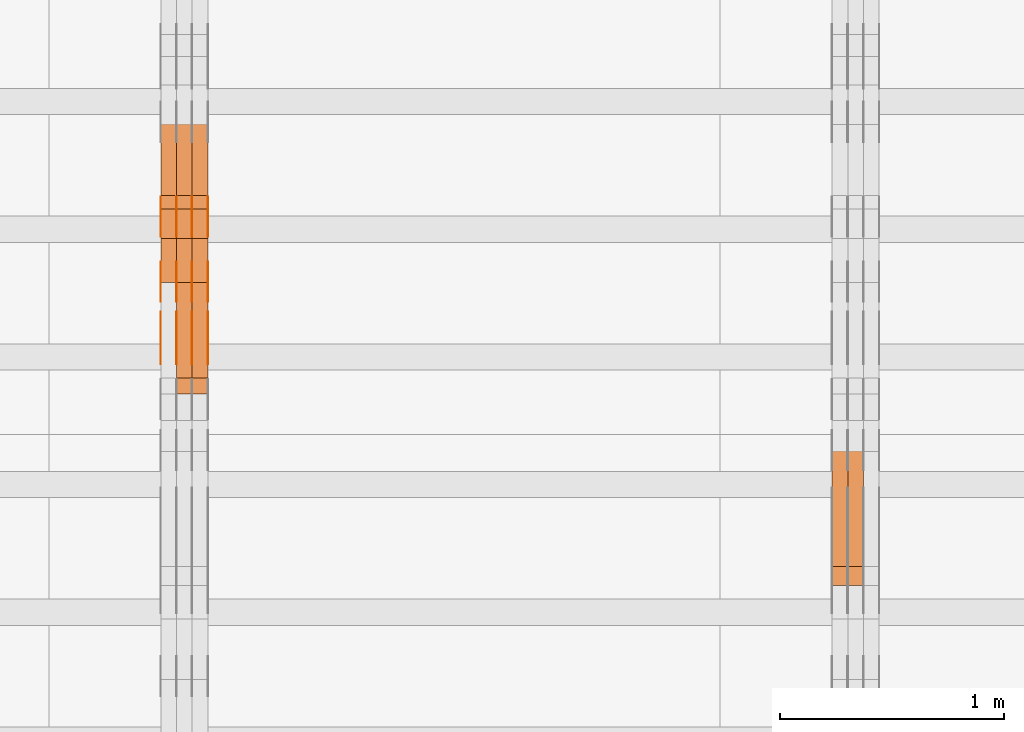
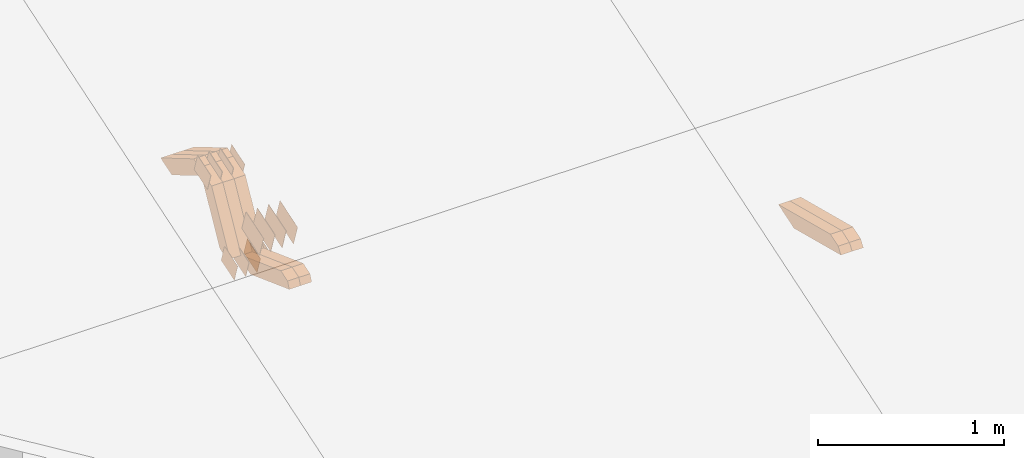
# One storey, part 135 of 385: 28 proxies.
"""IFC2X3 building model written with IfcOpenShell, lengths in millimetres."""

from ifc_helpers import new_model, entity, si_unit, converted_unit, derived_unit, direction, frame, origin, place, context, subcontext, project, spatial, polyline, outline, extrude, source, transform, mapped, material, type_object, type_shapes, element, save


model = new_model("IFC2X3")

# Units and contexts
model_context = context("Model", 3, precision=0.01, world=origin(), true_north=direction((6.12303176911189e-17, 1.0)))
body_context = subcontext(model_context, "Body", "Model", "MODEL_VIEW")
ifc_project = project(units=[si_unit("LENGTHUNIT", "METRE", prefix="MILLI"), si_unit("AREAUNIT", "SQUARE_METRE"), si_unit("VOLUMEUNIT", "CUBIC_METRE"), converted_unit("PLANEANGLEUNIT", "DEGREE", entity("IfcRatioMeasure", 0.0174532925199433), si_unit("PLANEANGLEUNIT", "RADIAN"), dimensions=[0, 0, 0, 0, 0, 0, 0]), si_unit("MASSUNIT", "GRAM", prefix="KILO"), derived_unit("MASSDENSITYUNIT", [(si_unit("MASSUNIT", "GRAM", prefix="KILO"), 1), (si_unit("LENGTHUNIT", "METRE"), -3)]), si_unit("TIMEUNIT", "SECOND"), si_unit("FREQUENCYUNIT", "HERTZ"), si_unit("THERMODYNAMICTEMPERATUREUNIT", "DEGREE_CELSIUS"), derived_unit("THERMALTRANSMITTANCEUNIT", [(si_unit("MASSUNIT", "GRAM", prefix="KILO"), 1), (si_unit("THERMODYNAMICTEMPERATUREUNIT", "KELVIN"), -1), (si_unit("TIMEUNIT", "SECOND"), -3)]), derived_unit("VOLUMETRICFLOWRATEUNIT", [(si_unit("LENGTHUNIT", "METRE"), 3), (si_unit("TIMEUNIT", "SECOND"), -1)]), si_unit("ELECTRICCURRENTUNIT", "AMPERE"), si_unit("ELECTRICVOLTAGEUNIT", "VOLT"), si_unit("POWERUNIT", "WATT"), si_unit("FORCEUNIT", "NEWTON", prefix="KILO"), si_unit("ILLUMINANCEUNIT", "LUX"), si_unit("LUMINOUSFLUXUNIT", "LUMEN"), si_unit("LUMINOUSINTENSITYUNIT", "CANDELA"), derived_unit("USERDEFINED", [(si_unit("MASSUNIT", "GRAM", prefix="KILO"), -1), (si_unit("LENGTHUNIT", "METRE"), -2), (si_unit("TIMEUNIT", "SECOND"), 3), (si_unit("LUMINOUSFLUXUNIT", "LUMEN"), 1)]), derived_unit("LINEARVELOCITYUNIT", [(si_unit("LENGTHUNIT", "METRE"), 1), (si_unit("TIMEUNIT", "SECOND"), -1)]), si_unit("PRESSUREUNIT", "PASCAL"), derived_unit("USERDEFINED", [(si_unit("LENGTHUNIT", "METRE"), -2), (si_unit("MASSUNIT", "GRAM", prefix="KILO"), 1), (si_unit("TIMEUNIT", "SECOND"), -2)])], contexts=[model_context])

# Site, building, storey
site_placement = place(None, origin())
site = spatial("IfcSite", under=ifc_project, at=site_placement, CompositionType="ELEMENT")
building_placement = place(site_placement, origin())
building = spatial("IfcBuilding", under=site, at=building_placement, CompositionType="ELEMENT")
storey_placement = place(building_placement, origin())
storey = spatial("IfcBuildingStorey", under=building, at=storey_placement, Name="Default", CompositionType="ELEMENT", Elevation=0.0)

# Proxies
ifc_material_1 = material(Name="IfcSurfaceStyle #323078")
building_element_proxy_type_1 = type_object("IfcBuildingElementProxyType", Name="T1-W11 323076", PredefinedType="NOTDEFINED", material=ifc_material_1)
shared_shape_1 = source(origin(), body_context, "Body", "SweptSolid", [
    extrude(outline(polyline([(-261.366417792209, -47.5000378467523), (260.949520182121, -47.5000378467523), (242.928845159301, -7.41559889341215e-06), (168.237407166939, 47.5000415545517), (-410.749354716152, 47.5000415545517), (-261.366417792209, -47.5000378467523)])), frame((260.949520182121, 47.5000415545517, 0.0), z_axis=(0.0, 0.0, 1.0), x_axis=(-1.0, 0.0, 0.0)), (0.0, 0.0, 1.0), 70.0),
])
type_shapes(building_element_proxy_type_1, [shared_shape_1])
proxy_1_placement = place(building_placement, frame((27315.0, 8017.44318793234, 2097.03832883996), z_axis=(-1.0, 0.0, 0.0), x_axis=(0.0, 0.968347201599873, -0.249607085543851)))
element("IfcBuildingElementProxy", 1, at=proxy_1_placement, inside=storey, type_object=building_element_proxy_type_1, material=ifc_material_1, Name="T1-W11", context=body_context, shape_type="MappedRepresentation", body=[
    mapped(shared_shape_1, transform((0.0, 0.0, 0.0), scale=1.0)),
])
ifc_material_2 = material(Name="IfcSurfaceStyle #323012")
building_element_proxy_type_2 = type_object("IfcBuildingElementProxyType", Name="T1-W11 323010", PredefinedType="NOTDEFINED", material=ifc_material_2)
shared_shape_2 = source(origin(), body_context, "Body", "SweptSolid", [
    extrude(outline(polyline([(-261.366417792209, -47.5000378467523), (260.949520182121, -47.5000378467523), (242.928845159301, -7.41559889341215e-06), (168.237407166939, 47.5000415545517), (-410.749354716152, 47.5000415545517), (-261.366417792209, -47.5000378467523)])), frame((260.949520182121, 47.5000415545517, 0.0), z_axis=(0.0, 0.0, 1.0), x_axis=(-1.0, 0.0, 0.0)), (0.0, 0.0, 1.0), 70.0),
])
type_shapes(building_element_proxy_type_2, [shared_shape_2])
proxy_2_placement = place(building_placement, frame((27245.0, 8017.44318793234, 2097.03832883996), z_axis=(-1.0, 0.0, 0.0), x_axis=(0.0, 0.968347201599873, -0.249607085543851)))
element("IfcBuildingElementProxy", 2, at=proxy_2_placement, inside=storey, type_object=building_element_proxy_type_2, material=ifc_material_2, Name="T1-W11", context=body_context, shape_type="MappedRepresentation", body=[
    mapped(shared_shape_2, transform((0.0, 0.0, 0.0), scale=1.0)),
])
ifc_material_3 = material(Name="IfcSurfaceStyle #314830")
building_element_proxy_type_3 = type_object("IfcBuildingElementProxyType", PredefinedType="NOTDEFINED", material=ifc_material_3)
shared_shape_3 = source(origin(), body_context, "Body", "SweptSolid", [
    extrude(outline(polyline([(-99.999644645517, -72.0000317581407), (100.000028485991, -72.0000317581407), (99.999644645517, 72.0000317581407), (-100.000028485991, 72.0000317581407), (-99.999644645517, -72.0000317581407)])), frame((100.000028485991, 72.0000317581407, 0.0), z_axis=(0.0, 0.0, 1.0), x_axis=(-1.0, 0.0, 0.0)), (0.0, 0.0, 1.0), 1.3),
])
type_shapes(building_element_proxy_type_3, [shared_shape_3])
proxy_3_placement = place(building_placement, frame((24386.3, 9012.6304394324, 2546.30522609783), z_axis=(-1.0, 0.0, 0.0), x_axis=(0.0, 0.951056516295154, 0.309016994374948)))
element("IfcBuildingElementProxy", 3, at=proxy_3_placement, inside=storey, type_object=building_element_proxy_type_3, material=ifc_material_3, context=body_context, shape_type="MappedRepresentation", body=[
    mapped(shared_shape_3, transform((0.0, 0.0, 0.0), scale=1.0)),
])
ifc_material_4 = material(Name="IfcSurfaceStyle #314773")
building_element_proxy_type_4 = type_object("IfcBuildingElementProxyType", PredefinedType="NOTDEFINED", material=ifc_material_4)
shared_shape_4 = source(origin(), body_context, "Body", "SweptSolid", [
    extrude(outline(polyline([(-99.999644645517, -72.0000317581407), (100.000028485991, -72.0000317581407), (99.999644645517, 72.0000317581407), (-100.000028485991, 72.0000317581407), (-99.999644645517, -72.0000317581407)])), frame((100.000028485991, 72.0000317581407, 0.0), z_axis=(0.0, 0.0, 1.0), x_axis=(-1.0, 0.0, 0.0)), (0.0, 0.0, 1.0), 1.3),
])
type_shapes(building_element_proxy_type_4, [shared_shape_4])
proxy_4_placement = place(building_placement, frame((24315.0, 9012.6304394324, 2546.30522609783), z_axis=(-1.0, 0.0, 0.0), x_axis=(0.0, 0.951056516295154, 0.309016994374948)))
element("IfcBuildingElementProxy", 4, at=proxy_4_placement, inside=storey, type_object=building_element_proxy_type_4, material=ifc_material_4, context=body_context, shape_type="MappedRepresentation", body=[
    mapped(shared_shape_4, transform((0.0, 0.0, 0.0), scale=1.0)),
])
ifc_material_5 = material(Name="IfcSurfaceStyle #314716")
building_element_proxy_type_5 = type_object("IfcBuildingElementProxyType", PredefinedType="NOTDEFINED", material=ifc_material_5)
shared_shape_5 = source(origin(), body_context, "Body", "SweptSolid", [
    extrude(outline(polyline([(-99.999644645517, -72.0000317581407), (100.000028485991, -72.0000317581407), (99.999644645517, 72.0000317581407), (-100.000028485991, 72.0000317581407), (-99.999644645517, -72.0000317581407)])), frame((100.000028485991, 72.0000317581407, 0.0), z_axis=(0.0, 0.0, 1.0), x_axis=(-1.0, 0.0, 0.0)), (0.0, 0.0, 1.0), 1.3),
])
type_shapes(building_element_proxy_type_5, [shared_shape_5])
proxy_5_placement = place(building_placement, frame((24316.3, 9012.6304394324, 2546.30522609783), z_axis=(-1.0, 0.0, 0.0), x_axis=(0.0, 0.951056516295154, 0.309016994374948)))
element("IfcBuildingElementProxy", 5, at=proxy_5_placement, inside=storey, type_object=building_element_proxy_type_5, material=ifc_material_5, context=body_context, shape_type="MappedRepresentation", body=[
    mapped(shared_shape_5, transform((0.0, 0.0, 0.0), scale=1.0)),
])
ifc_material_6 = material(Name="IfcSurfaceStyle #314659")
building_element_proxy_type_6 = type_object("IfcBuildingElementProxyType", PredefinedType="NOTDEFINED", material=ifc_material_6)
shared_shape_6 = source(origin(), body_context, "Body", "SweptSolid", [
    extrude(outline(polyline([(-99.999644645517, -72.0000317581407), (100.000028485991, -72.0000317581407), (99.999644645517, 72.0000317581407), (-100.000028485991, 72.0000317581407), (-99.999644645517, -72.0000317581407)])), frame((100.000028485991, 72.0000317581407, 0.0), z_axis=(0.0, 0.0, 1.0), x_axis=(-1.0, 0.0, 0.0)), (0.0, 0.0, 1.0), 1.29999999999998),
])
type_shapes(building_element_proxy_type_6, [shared_shape_6])
proxy_6_placement = place(building_placement, frame((24245.0, 9012.6304394324, 2546.30522609783), z_axis=(-1.0, 0.0, 0.0), x_axis=(0.0, 0.951056516295154, 0.309016994374948)))
element("IfcBuildingElementProxy", 6, at=proxy_6_placement, inside=storey, type_object=building_element_proxy_type_6, material=ifc_material_6, context=body_context, shape_type="MappedRepresentation", body=[
    mapped(shared_shape_6, transform((0.0, 0.0, 0.0), scale=1.0)),
])
ifc_material_7 = material(Name="IfcSurfaceStyle #314602")
building_element_proxy_type_7 = type_object("IfcBuildingElementProxyType", PredefinedType="NOTDEFINED", material=ifc_material_7)
shared_shape_7 = source(origin(), body_context, "Body", "SweptSolid", [
    extrude(outline(polyline([(-99.999644645517, -72.0000317581407), (100.000028485991, -72.0000317581407), (99.999644645517, 72.0000317581407), (-100.000028485991, 72.0000317581407), (-99.999644645517, -72.0000317581407)])), frame((100.000028485991, 72.0000317581407, 0.0), z_axis=(0.0, 0.0, 1.0), x_axis=(-1.0, 0.0, 0.0)), (0.0, 0.0, 1.0), 1.29999999999998),
])
type_shapes(building_element_proxy_type_7, [shared_shape_7])
proxy_7_placement = place(building_placement, frame((24246.3, 9012.6304394324, 2546.30522609783), z_axis=(-1.0, 0.0, 0.0), x_axis=(0.0, 0.951056516295154, 0.309016994374948)))
element("IfcBuildingElementProxy", 7, at=proxy_7_placement, inside=storey, type_object=building_element_proxy_type_7, material=ifc_material_7, context=body_context, shape_type="MappedRepresentation", body=[
    mapped(shared_shape_7, transform((0.0, 0.0, 0.0), scale=1.0)),
])
ifc_material_8 = material(Name="IfcSurfaceStyle #314545")
building_element_proxy_type_8 = type_object("IfcBuildingElementProxyType", PredefinedType="NOTDEFINED", material=ifc_material_8)
shared_shape_8 = source(origin(), body_context, "Body", "SweptSolid", [
    extrude(outline(polyline([(-99.999644645517, -72.0000317581407), (100.000028485991, -72.0000317581407), (99.999644645517, 72.0000317581407), (-100.000028485991, 72.0000317581407), (-99.999644645517, -72.0000317581407)])), frame((100.000028485991, 72.0000317581407, 0.0), z_axis=(0.0, 0.0, 1.0), x_axis=(-1.0, 0.0, 0.0)), (0.0, 0.0, 1.0), 1.29999999999999),
])
type_shapes(building_element_proxy_type_8, [shared_shape_8])
proxy_8_placement = place(building_placement, frame((24175.0, 9012.6304394324, 2546.30522609783), z_axis=(-1.0, 0.0, 0.0), x_axis=(0.0, 0.951056516295154, 0.309016994374948)))
element("IfcBuildingElementProxy", 8, at=proxy_8_placement, inside=storey, type_object=building_element_proxy_type_8, material=ifc_material_8, context=body_context, shape_type="MappedRepresentation", body=[
    mapped(shared_shape_8, transform((0.0, 0.0, 0.0), scale=1.0)),
])
ifc_material_9 = material(Name="IfcSurfaceStyle #314488")
building_element_proxy_type_9 = type_object("IfcBuildingElementProxyType", PredefinedType="NOTDEFINED", material=ifc_material_9)
shared_shape_9 = source(origin(), body_context, "Body", "SweptSolid", [
    extrude(outline(polyline([(-74.9998754286207, -60.0000016373506), (74.9998605591063, -60.0000016373506), (74.9998754286244, 60.0000016373506), (-74.9998605591099, 60.0000016373506), (-74.9998754286207, -60.0000016373506)])), frame((74.9998754286244, 60.0000016373506, 0.0), z_axis=(0.0, 0.0, 1.0), x_axis=(-1.0, 0.0, 0.0)), (0.0, 0.0, 1.0), 1.3),
])
type_shapes(building_element_proxy_type_9, [shared_shape_9])
proxy_9_placement = place(building_placement, frame((24386.3, 9580.89841427132, 2615.81135078741), z_axis=(-1.0, 0.0, 0.0), x_axis=(0.0, 0.951056516295154, 0.309016994374948)))
element("IfcBuildingElementProxy", 9, at=proxy_9_placement, inside=storey, type_object=building_element_proxy_type_9, material=ifc_material_9, context=body_context, shape_type="MappedRepresentation", body=[
    mapped(shared_shape_9, transform((0.0, 0.0, 0.0), scale=1.0)),
])
ifc_material_10 = material(Name="IfcSurfaceStyle #314431")
building_element_proxy_type_10 = type_object("IfcBuildingElementProxyType", PredefinedType="NOTDEFINED", material=ifc_material_10)
shared_shape_10 = source(origin(), body_context, "Body", "SweptSolid", [
    extrude(outline(polyline([(-74.9998754286207, -60.0000016373506), (74.9998605591063, -60.0000016373506), (74.9998754286244, 60.0000016373506), (-74.9998605591099, 60.0000016373506), (-74.9998754286207, -60.0000016373506)])), frame((74.9998754286244, 60.0000016373506, 0.0), z_axis=(0.0, 0.0, 1.0), x_axis=(-1.0, 0.0, 0.0)), (0.0, 0.0, 1.0), 1.3),
])
type_shapes(building_element_proxy_type_10, [shared_shape_10])
proxy_10_placement = place(building_placement, frame((24315.0, 9580.89841427132, 2615.81135078741), z_axis=(-1.0, 0.0, 0.0), x_axis=(0.0, 0.951056516295154, 0.309016994374948)))
element("IfcBuildingElementProxy", 10, at=proxy_10_placement, inside=storey, type_object=building_element_proxy_type_10, material=ifc_material_10, context=body_context, shape_type="MappedRepresentation", body=[
    mapped(shared_shape_10, transform((0.0, 0.0, 0.0), scale=1.0)),
])
ifc_material_11 = material(Name="IfcSurfaceStyle #314374")
building_element_proxy_type_11 = type_object("IfcBuildingElementProxyType", PredefinedType="NOTDEFINED", material=ifc_material_11)
shared_shape_11 = source(origin(), body_context, "Body", "SweptSolid", [
    extrude(outline(polyline([(-74.9998754286207, -60.0000016373506), (74.9998605591063, -60.0000016373506), (74.9998754286244, 60.0000016373506), (-74.9998605591099, 60.0000016373506), (-74.9998754286207, -60.0000016373506)])), frame((74.9998754286244, 60.0000016373506, 0.0), z_axis=(0.0, 0.0, 1.0), x_axis=(-1.0, 0.0, 0.0)), (0.0, 0.0, 1.0), 1.3),
])
type_shapes(building_element_proxy_type_11, [shared_shape_11])
proxy_11_placement = place(building_placement, frame((24316.3, 9580.89841427132, 2615.81135078741), z_axis=(-1.0, 0.0, 0.0), x_axis=(0.0, 0.951056516295154, 0.309016994374948)))
element("IfcBuildingElementProxy", 11, at=proxy_11_placement, inside=storey, type_object=building_element_proxy_type_11, material=ifc_material_11, context=body_context, shape_type="MappedRepresentation", body=[
    mapped(shared_shape_11, transform((0.0, 0.0, 0.0), scale=1.0)),
])
ifc_material_12 = material(Name="IfcSurfaceStyle #314317")
building_element_proxy_type_12 = type_object("IfcBuildingElementProxyType", PredefinedType="NOTDEFINED", material=ifc_material_12)
shared_shape_12 = source(origin(), body_context, "Body", "SweptSolid", [
    extrude(outline(polyline([(-74.9998754286207, -60.0000016373506), (74.9998605591063, -60.0000016373506), (74.9998754286244, 60.0000016373506), (-74.9998605591099, 60.0000016373506), (-74.9998754286207, -60.0000016373506)])), frame((74.9998754286244, 60.0000016373506, 0.0), z_axis=(0.0, 0.0, 1.0), x_axis=(-1.0, 0.0, 0.0)), (0.0, 0.0, 1.0), 1.29999999999999),
])
type_shapes(building_element_proxy_type_12, [shared_shape_12])
proxy_12_placement = place(building_placement, frame((24245.0, 9580.89841427132, 2615.81135078741), z_axis=(-1.0, 0.0, 0.0), x_axis=(0.0, 0.951056516295154, 0.309016994374948)))
element("IfcBuildingElementProxy", 12, at=proxy_12_placement, inside=storey, type_object=building_element_proxy_type_12, material=ifc_material_12, context=body_context, shape_type="MappedRepresentation", body=[
    mapped(shared_shape_12, transform((0.0, 0.0, 0.0), scale=1.0)),
])
ifc_material_13 = material(Name="IfcSurfaceStyle #314260")
building_element_proxy_type_13 = type_object("IfcBuildingElementProxyType", PredefinedType="NOTDEFINED", material=ifc_material_13)
shared_shape_13 = source(origin(), body_context, "Body", "SweptSolid", [
    extrude(outline(polyline([(-74.9998754286207, -60.0000016373506), (74.9998605591063, -60.0000016373506), (74.9998754286244, 60.0000016373506), (-74.9998605591099, 60.0000016373506), (-74.9998754286207, -60.0000016373506)])), frame((74.9998754286244, 60.0000016373506, 0.0), z_axis=(0.0, 0.0, 1.0), x_axis=(-1.0, 0.0, 0.0)), (0.0, 0.0, 1.0), 1.29999999999999),
])
type_shapes(building_element_proxy_type_13, [shared_shape_13])
proxy_13_placement = place(building_placement, frame((24246.3, 9580.89841427132, 2615.81135078741), z_axis=(-1.0, 0.0, 0.0), x_axis=(0.0, 0.951056516295154, 0.309016994374948)))
element("IfcBuildingElementProxy", 13, at=proxy_13_placement, inside=storey, type_object=building_element_proxy_type_13, material=ifc_material_13, context=body_context, shape_type="MappedRepresentation", body=[
    mapped(shared_shape_13, transform((0.0, 0.0, 0.0), scale=1.0)),
])
ifc_material_14 = material(Name="IfcSurfaceStyle #314203")
building_element_proxy_type_14 = type_object("IfcBuildingElementProxyType", PredefinedType="NOTDEFINED", material=ifc_material_14)
shared_shape_14 = source(origin(), body_context, "Body", "SweptSolid", [
    extrude(outline(polyline([(-74.9998754286207, -60.0000016373506), (74.9998605591063, -60.0000016373506), (74.9998754286244, 60.0000016373506), (-74.9998605591099, 60.0000016373506), (-74.9998754286207, -60.0000016373506)])), frame((74.9998754286244, 60.0000016373506, 0.0), z_axis=(0.0, 0.0, 1.0), x_axis=(-1.0, 0.0, 0.0)), (0.0, 0.0, 1.0), 1.29999999999999),
])
type_shapes(building_element_proxy_type_14, [shared_shape_14])
proxy_14_placement = place(building_placement, frame((24175.0, 9580.89841427132, 2615.81135078741), z_axis=(-1.0, 0.0, 0.0), x_axis=(0.0, 0.951056516295154, 0.309016994374948)))
element("IfcBuildingElementProxy", 14, at=proxy_14_placement, inside=storey, type_object=building_element_proxy_type_14, material=ifc_material_14, context=body_context, shape_type="MappedRepresentation", body=[
    mapped(shared_shape_14, transform((0.0, 0.0, 0.0), scale=1.0)),
])
ifc_material_15 = material(Name="IfcSurfaceStyle #313462")
building_element_proxy_type_15 = type_object("IfcBuildingElementProxyType", PredefinedType="NOTDEFINED", material=ifc_material_15)
shared_shape_15 = source(origin(), body_context, "Body", "SweptSolid", [
    extrude(outline(polyline([(-75.0008041947458, -59.9996998629349), (75.0007893252423, -59.9996998629349), (75.0008041947458, 59.9996998629349), (-75.0007893252423, 59.9996998629349), (-75.0008041947458, -59.9996998629349)])), frame((75.0008041947458, 60.0002282421692, 0.0), z_axis=(0.0, 0.0, 1.0), x_axis=(-1.0, 0.0, 0.0)), (0.0, 0.0, 1.0), 1.3),
])
type_shapes(building_element_proxy_type_15, [shared_shape_15])
proxy_15_placement = place(building_placement, frame((24386.3, 9291.048828125, 2194.94482421875), z_axis=(-1.0, 0.0, 0.0), x_axis=(0.0, 0.951056516295124, 0.309016994375039)))
element("IfcBuildingElementProxy", 15, at=proxy_15_placement, inside=storey, type_object=building_element_proxy_type_15, material=ifc_material_15, context=body_context, shape_type="MappedRepresentation", body=[
    mapped(shared_shape_15, transform((0.0, 0.0, 0.0), scale=1.0)),
])
ifc_material_16 = material(Name="IfcSurfaceStyle #313405")
building_element_proxy_type_16 = type_object("IfcBuildingElementProxyType", PredefinedType="NOTDEFINED", material=ifc_material_16)
shared_shape_16 = source(origin(), body_context, "Body", "SweptSolid", [
    extrude(outline(polyline([(-75.0008041947458, -59.9996998629349), (75.0007893252423, -59.9996998629349), (75.0008041947458, 59.9996998629349), (-75.0007893252423, 59.9996998629349), (-75.0008041947458, -59.9996998629349)])), frame((75.0008041947458, 60.0002282421692, 0.0), z_axis=(0.0, 0.0, 1.0), x_axis=(-1.0, 0.0, 0.0)), (0.0, 0.0, 1.0), 1.3),
])
type_shapes(building_element_proxy_type_16, [shared_shape_16])
proxy_16_placement = place(building_placement, frame((24315.0, 9291.048828125, 2194.94482421875), z_axis=(-1.0, 0.0, 0.0), x_axis=(0.0, 0.951056516295124, 0.309016994375039)))
element("IfcBuildingElementProxy", 16, at=proxy_16_placement, inside=storey, type_object=building_element_proxy_type_16, material=ifc_material_16, context=body_context, shape_type="MappedRepresentation", body=[
    mapped(shared_shape_16, transform((0.0, 0.0, 0.0), scale=1.0)),
])
ifc_material_17 = material(Name="IfcSurfaceStyle #313348")
building_element_proxy_type_17 = type_object("IfcBuildingElementProxyType", PredefinedType="NOTDEFINED", material=ifc_material_17)
shared_shape_17 = source(origin(), body_context, "Body", "SweptSolid", [
    extrude(outline(polyline([(-75.0008041947458, -59.9996998629349), (75.0007893252423, -59.9996998629349), (75.0008041947458, 59.9996998629349), (-75.0007893252423, 59.9996998629349), (-75.0008041947458, -59.9996998629349)])), frame((75.0008041947458, 60.0002282421692, 0.0), z_axis=(0.0, 0.0, 1.0), x_axis=(-1.0, 0.0, 0.0)), (0.0, 0.0, 1.0), 1.3),
])
type_shapes(building_element_proxy_type_17, [shared_shape_17])
proxy_17_placement = place(building_placement, frame((24316.3, 9291.048828125, 2194.94482421875), z_axis=(-1.0, 0.0, 0.0), x_axis=(0.0, 0.951056516295124, 0.309016994375039)))
element("IfcBuildingElementProxy", 17, at=proxy_17_placement, inside=storey, type_object=building_element_proxy_type_17, material=ifc_material_17, context=body_context, shape_type="MappedRepresentation", body=[
    mapped(shared_shape_17, transform((0.0, 0.0, 0.0), scale=1.0)),
])
ifc_material_18 = material(Name="IfcSurfaceStyle #313291")
building_element_proxy_type_18 = type_object("IfcBuildingElementProxyType", PredefinedType="NOTDEFINED", material=ifc_material_18)
shared_shape_18 = source(origin(), body_context, "Body", "SweptSolid", [
    extrude(outline(polyline([(-75.0008041947458, -59.9996998629349), (75.0007893252423, -59.9996998629349), (75.0008041947458, 59.9996998629349), (-75.0007893252423, 59.9996998629349), (-75.0008041947458, -59.9996998629349)])), frame((75.0008041947458, 60.0002282421692, 0.0), z_axis=(0.0, 0.0, 1.0), x_axis=(-1.0, 0.0, 0.0)), (0.0, 0.0, 1.0), 1.29999999999999),
])
type_shapes(building_element_proxy_type_18, [shared_shape_18])
proxy_18_placement = place(building_placement, frame((24245.0, 9291.048828125, 2194.94482421875), z_axis=(-1.0, 0.0, 0.0), x_axis=(0.0, 0.951056516295124, 0.309016994375039)))
element("IfcBuildingElementProxy", 18, at=proxy_18_placement, inside=storey, type_object=building_element_proxy_type_18, material=ifc_material_18, context=body_context, shape_type="MappedRepresentation", body=[
    mapped(shared_shape_18, transform((0.0, 0.0, 0.0), scale=1.0)),
])
ifc_material_19 = material(Name="IfcSurfaceStyle #313234")
building_element_proxy_type_19 = type_object("IfcBuildingElementProxyType", PredefinedType="NOTDEFINED", material=ifc_material_19)
shared_shape_19 = source(origin(), body_context, "Body", "SweptSolid", [
    extrude(outline(polyline([(-75.0008041947458, -59.9996998629349), (75.0007893252423, -59.9996998629349), (75.0008041947458, 59.9996998629349), (-75.0007893252423, 59.9996998629349), (-75.0008041947458, -59.9996998629349)])), frame((75.0008041947458, 60.0002282421692, 0.0), z_axis=(0.0, 0.0, 1.0), x_axis=(-1.0, 0.0, 0.0)), (0.0, 0.0, 1.0), 1.29999999999999),
])
type_shapes(building_element_proxy_type_19, [shared_shape_19])
proxy_19_placement = place(building_placement, frame((24246.3, 9291.048828125, 2194.94482421875), z_axis=(-1.0, 0.0, 0.0), x_axis=(0.0, 0.951056516295124, 0.309016994375039)))
element("IfcBuildingElementProxy", 19, at=proxy_19_placement, inside=storey, type_object=building_element_proxy_type_19, material=ifc_material_19, context=body_context, shape_type="MappedRepresentation", body=[
    mapped(shared_shape_19, transform((0.0, 0.0, 0.0), scale=1.0)),
])
ifc_material_20 = material(Name="IfcSurfaceStyle #313177")
building_element_proxy_type_20 = type_object("IfcBuildingElementProxyType", PredefinedType="NOTDEFINED", material=ifc_material_20)
shared_shape_20 = source(origin(), body_context, "Body", "SweptSolid", [
    extrude(outline(polyline([(-75.0008041947458, -59.9996998629349), (75.0007893252423, -59.9996998629349), (75.0008041947458, 59.9996998629349), (-75.0007893252423, 59.9996998629349), (-75.0008041947458, -59.9996998629349)])), frame((75.0008041947458, 60.0002282421692, 0.0), z_axis=(0.0, 0.0, 1.0), x_axis=(-1.0, 0.0, 0.0)), (0.0, 0.0, 1.0), 1.29999999999999),
])
type_shapes(building_element_proxy_type_20, [shared_shape_20])
proxy_20_placement = place(building_placement, frame((24175.0, 9291.048828125, 2194.94482421875), z_axis=(-1.0, 0.0, 0.0), x_axis=(0.0, 0.951056516295124, 0.309016994375039)))
element("IfcBuildingElementProxy", 20, at=proxy_20_placement, inside=storey, type_object=building_element_proxy_type_20, material=ifc_material_20, context=body_context, shape_type="MappedRepresentation", body=[
    mapped(shared_shape_20, transform((0.0, 0.0, 0.0), scale=1.0)),
])
ifc_material_21 = material(Name="IfcSurfaceStyle #290296")
building_element_proxy_type_21 = type_object("IfcBuildingElementProxyType", Name="T1-W43 290294", PredefinedType="NOTDEFINED", material=ifc_material_21)
shared_shape_21 = source(origin(), body_context, "Body", "SweptSolid", [
    extrude(outline(polyline([(-198.159905426436, -47.4999961988362), (173.155878681738, -47.4999961988362), (174.585865234707, -0.00038778214839239), (132.582704932703, 47.5001900899104), (-282.164543422712, 47.5001900899104), (-198.159905426436, -47.4999961988362)])), frame((174.585865234707, 47.5001900899104, 0.0), z_axis=(0.0, 0.0, 1.0), x_axis=(-1.0, 0.0, 0.0)), (0.0, 0.0, 1.0), 70.0),
])
type_shapes(building_element_proxy_type_21, [shared_shape_21])
proxy_21_placement = place(building_placement, frame((24385.0, 9730.71877771152, 2634.4881681647), z_axis=(-1.0, 0.0, 0.0), x_axis=(0.0, 0.861495156633645, -0.507765787639115)))
element("IfcBuildingElementProxy", 21, at=proxy_21_placement, inside=storey, type_object=building_element_proxy_type_21, material=ifc_material_21, Name="T1-W43", context=body_context, shape_type="MappedRepresentation", body=[
    mapped(shared_shape_21, transform((0.0, 0.0, 0.0), scale=1.0)),
])
ifc_material_22 = material(Name="IfcSurfaceStyle #290230")
building_element_proxy_type_22 = type_object("IfcBuildingElementProxyType", Name="T1-W43 290228", PredefinedType="NOTDEFINED", material=ifc_material_22)
shared_shape_22 = source(origin(), body_context, "Body", "SweptSolid", [
    extrude(outline(polyline([(-198.159905426436, -47.4999961988362), (173.155878681738, -47.4999961988362), (174.585865234707, -0.00038778214839239), (132.582704932703, 47.5001900899104), (-282.164543422712, 47.5001900899104), (-198.159905426436, -47.4999961988362)])), frame((174.585865234707, 47.5001900899104, 0.0), z_axis=(0.0, 0.0, 1.0), x_axis=(-1.0, 0.0, 0.0)), (0.0, 0.0, 1.0), 70.0),
])
type_shapes(building_element_proxy_type_22, [shared_shape_22])
proxy_22_placement = place(building_placement, frame((24315.0, 9730.71877771152, 2634.4881681647), z_axis=(-1.0, 0.0, 0.0), x_axis=(0.0, 0.861495156633645, -0.507765787639115)))
element("IfcBuildingElementProxy", 22, at=proxy_22_placement, inside=storey, type_object=building_element_proxy_type_22, material=ifc_material_22, Name="T1-W43", context=body_context, shape_type="MappedRepresentation", body=[
    mapped(shared_shape_22, transform((0.0, 0.0, 0.0), scale=1.0)),
])
ifc_material_23 = material(Name="IfcSurfaceStyle #290164")
building_element_proxy_type_23 = type_object("IfcBuildingElementProxyType", Name="T1-W43 290162", PredefinedType="NOTDEFINED", material=ifc_material_23)
shared_shape_23 = source(origin(), body_context, "Body", "SweptSolid", [
    extrude(outline(polyline([(-198.159905426436, -47.4999961988362), (173.155878681738, -47.4999961988362), (174.585865234707, -0.00038778214839239), (132.582704932703, 47.5001900899104), (-282.164543422712, 47.5001900899104), (-198.159905426436, -47.4999961988362)])), frame((174.585865234707, 47.5001900899104, 0.0), z_axis=(0.0, 0.0, 1.0), x_axis=(-1.0, 0.0, 0.0)), (0.0, 0.0, 1.0), 70.0),
])
type_shapes(building_element_proxy_type_23, [shared_shape_23])
proxy_23_placement = place(building_placement, frame((24245.0, 9730.71877771152, 2634.4881681647), z_axis=(-1.0, 0.0, 0.0), x_axis=(0.0, 0.861495156633645, -0.507765787639115)))
element("IfcBuildingElementProxy", 23, at=proxy_23_placement, inside=storey, type_object=building_element_proxy_type_23, material=ifc_material_23, Name="T1-W43", context=body_context, shape_type="MappedRepresentation", body=[
    mapped(shared_shape_23, transform((0.0, 0.0, 0.0), scale=1.0)),
])
ifc_material_24 = material(Name="IfcSurfaceStyle #289900")
building_element_proxy_type_24 = type_object("IfcBuildingElementProxyType", Name="T1-W33 289898", PredefinedType="NOTDEFINED", material=ifc_material_24)
shared_shape_24 = source(origin(), body_context, "Body", "SweptSolid", [
    extrude(outline(polyline([(-314.173070820175, -47.4997758466969), (139.635944117881, -47.4997758466969), (190.204920608233, 0.000348187720347082), (197.369205310989, 47.5001702328475), (-213.036999216928, 47.4990332728259), (-314.173070820175, -47.4997758466969)])), frame((197.369205310989, 47.5001702328475, 0.0), z_axis=(0.0, 0.0, 1.0), x_axis=(-1.0, 0.0, 0.0)), (0.0, 0.0, 1.0), 70.0),
])
type_shapes(building_element_proxy_type_24, [shared_shape_24])
proxy_24_placement = place(building_placement, frame((24385.0, 9376.96875, 2191.01977539063), z_axis=(-1.0, 0.0, 0.0), x_axis=(0.0, 0.481632628948835, 0.876373214293907)))
element("IfcBuildingElementProxy", 24, at=proxy_24_placement, inside=storey, type_object=building_element_proxy_type_24, material=ifc_material_24, Name="T1-W33", context=body_context, shape_type="MappedRepresentation", body=[
    mapped(shared_shape_24, transform((0.0, 0.0, 0.0), scale=1.0)),
])
ifc_material_25 = material(Name="IfcSurfaceStyle #289834")
building_element_proxy_type_25 = type_object("IfcBuildingElementProxyType", Name="T1-W33 289832", PredefinedType="NOTDEFINED", material=ifc_material_25)
shared_shape_25 = source(origin(), body_context, "Body", "SweptSolid", [
    extrude(outline(polyline([(-314.173070820175, -47.4997758466969), (139.635944117881, -47.4997758466969), (190.204920608233, 0.000348187720347082), (197.369205310989, 47.5001702328475), (-213.036999216928, 47.4990332728259), (-314.173070820175, -47.4997758466969)])), frame((197.369205310989, 47.5001702328475, 0.0), z_axis=(0.0, 0.0, 1.0), x_axis=(-1.0, 0.0, 0.0)), (0.0, 0.0, 1.0), 70.0),
])
type_shapes(building_element_proxy_type_25, [shared_shape_25])
proxy_25_placement = place(building_placement, frame((24315.0, 9376.96875, 2191.01977539063), z_axis=(-1.0, 0.0, 0.0), x_axis=(0.0, 0.481632628948835, 0.876373214293907)))
element("IfcBuildingElementProxy", 25, at=proxy_25_placement, inside=storey, type_object=building_element_proxy_type_25, material=ifc_material_25, Name="T1-W33", context=body_context, shape_type="MappedRepresentation", body=[
    mapped(shared_shape_25, transform((0.0, 0.0, 0.0), scale=1.0)),
])
ifc_material_26 = material(Name="IfcSurfaceStyle #289768")
building_element_proxy_type_26 = type_object("IfcBuildingElementProxyType", Name="T1-W33 289766", PredefinedType="NOTDEFINED", material=ifc_material_26)
shared_shape_26 = source(origin(), body_context, "Body", "SweptSolid", [
    extrude(outline(polyline([(-314.173070820175, -47.4997758466969), (139.635944117881, -47.4997758466969), (190.204920608233, 0.000348187720347082), (197.369205310989, 47.5001702328475), (-213.036999216928, 47.4990332728259), (-314.173070820175, -47.4997758466969)])), frame((197.369205310989, 47.5001702328475, 0.0), z_axis=(0.0, 0.0, 1.0), x_axis=(-1.0, 0.0, 0.0)), (0.0, 0.0, 1.0), 70.0),
])
type_shapes(building_element_proxy_type_26, [shared_shape_26])
proxy_26_placement = place(building_placement, frame((24245.0, 9376.96875, 2191.01977539063), z_axis=(-1.0, 0.0, 0.0), x_axis=(0.0, 0.481632628948835, 0.876373214293907)))
element("IfcBuildingElementProxy", 26, at=proxy_26_placement, inside=storey, type_object=building_element_proxy_type_26, material=ifc_material_26, Name="T1-W33", context=body_context, shape_type="MappedRepresentation", body=[
    mapped(shared_shape_26, transform((0.0, 0.0, 0.0), scale=1.0)),
])
ifc_material_27 = material(Name="IfcSurfaceStyle #289504")
building_element_proxy_type_27 = type_object("IfcBuildingElementProxyType", Name="T1-W25 289502", PredefinedType="NOTDEFINED", material=ifc_material_27)
shared_shape_27 = source(origin(), body_context, "Body", "SweptSolid", [
    extrude(outline(polyline([(-229.232772462784, -47.5001671709529), (214.075939394384, -47.5001671709529), (212.688957821661, -0.000141058964427199), (152.358910178478, 47.5002377004352), (-349.891034931738, 47.5002377004352), (-229.232772462784, -47.5001671709529)])), frame((214.075939394384, 47.5002377004352, 0.0), z_axis=(0.0, 0.0, 1.0), x_axis=(-1.0, 0.0, 0.0)), (0.0, 0.0, 1.0), 70.0),
])
type_shapes(building_element_proxy_type_27, [shared_shape_27])
proxy_27_placement = place(building_placement, frame((24385.0, 8892.81895960242, 2369.29665807578), z_axis=(-1.0, 0.0, 0.0), x_axis=(0.0, 0.938402514401222, -0.345544094097213)))
element("IfcBuildingElementProxy", 27, at=proxy_27_placement, inside=storey, type_object=building_element_proxy_type_27, material=ifc_material_27, Name="T1-W25", context=body_context, shape_type="MappedRepresentation", body=[
    mapped(shared_shape_27, transform((0.0, 0.0, 0.0), scale=1.0)),
])
ifc_material_28 = material(Name="IfcSurfaceStyle #289438")
building_element_proxy_type_28 = type_object("IfcBuildingElementProxyType", Name="T1-W25 289436", PredefinedType="NOTDEFINED", material=ifc_material_28)
shared_shape_28 = source(origin(), body_context, "Body", "SweptSolid", [
    extrude(outline(polyline([(-229.232772462784, -47.5001671709529), (214.075939394384, -47.5001671709529), (212.688957821661, -0.000141058964427199), (152.358910178478, 47.5002377004352), (-349.891034931738, 47.5002377004352), (-229.232772462784, -47.5001671709529)])), frame((214.075939394384, 47.5002377004352, 0.0), z_axis=(0.0, 0.0, 1.0), x_axis=(-1.0, 0.0, 0.0)), (0.0, 0.0, 1.0), 70.0),
])
type_shapes(building_element_proxy_type_28, [shared_shape_28])
proxy_28_placement = place(building_placement, frame((24315.0, 8892.81895960242, 2369.29665807578), z_axis=(-1.0, 0.0, 0.0), x_axis=(0.0, 0.938402514401222, -0.345544094097213)))
element("IfcBuildingElementProxy", 28, at=proxy_28_placement, inside=storey, type_object=building_element_proxy_type_28, material=ifc_material_28, Name="T1-W25", context=body_context, shape_type="MappedRepresentation", body=[
    mapped(shared_shape_28, transform((0.0, 0.0, 0.0), scale=1.0)),
])

save(model, "model.ifc")
